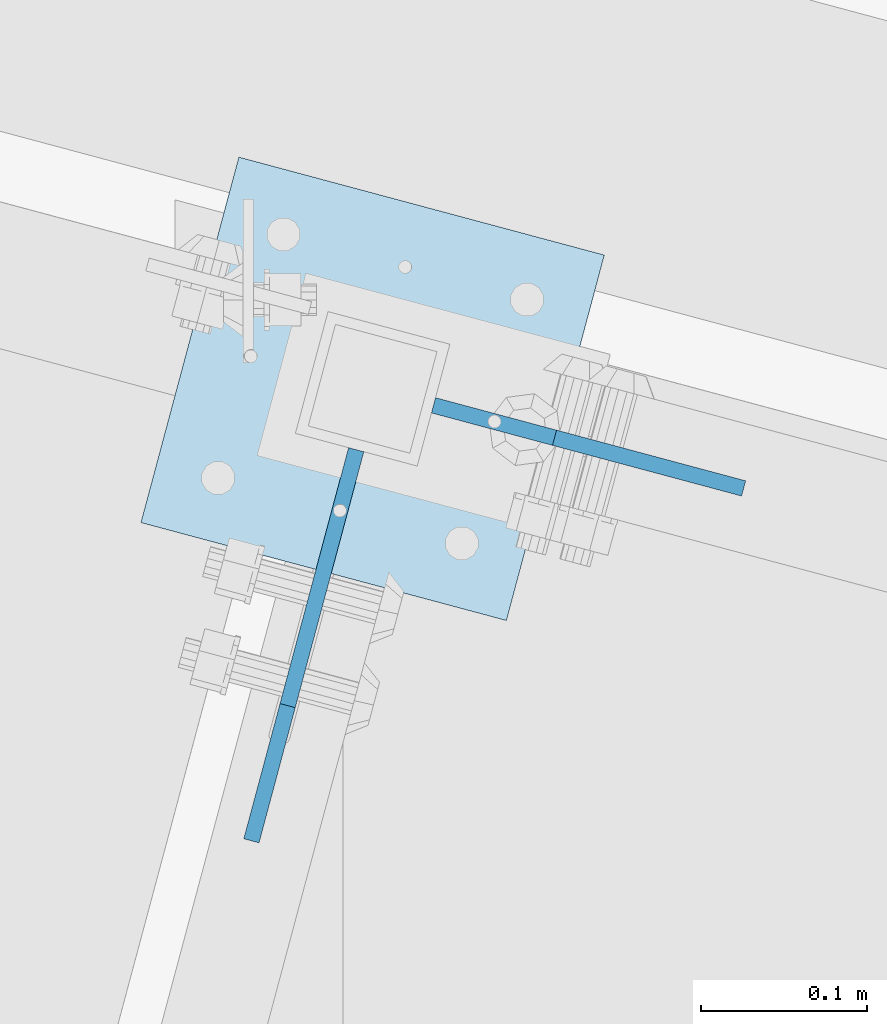
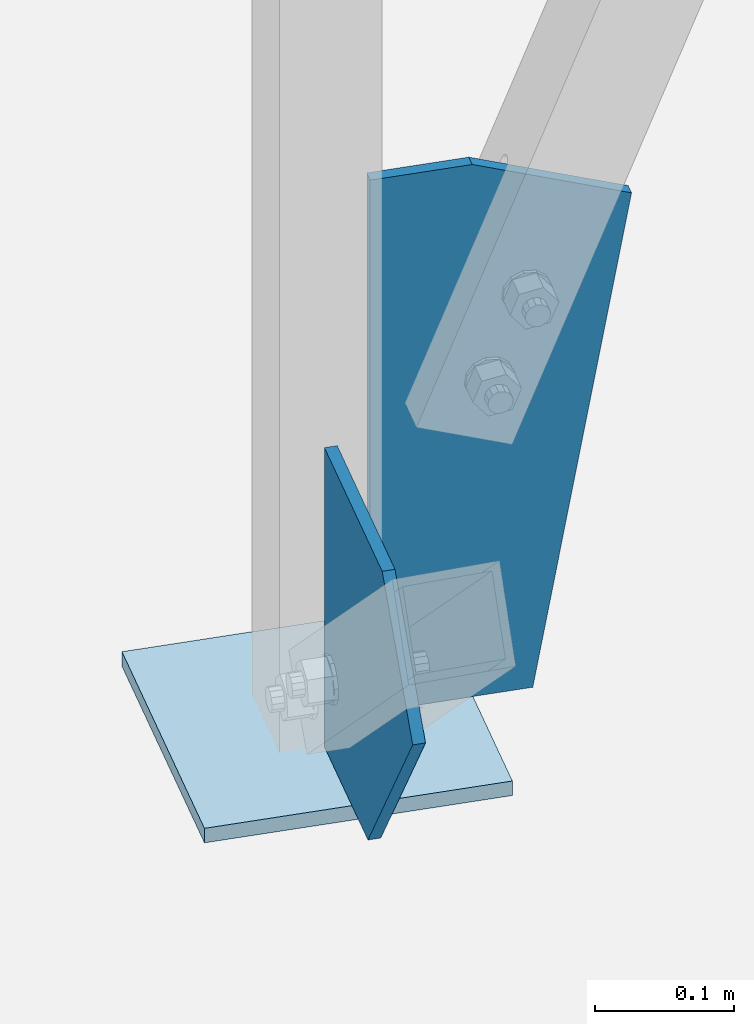
# One storey, part 1696 of 1763: 3 plates, 1 element without a shape of its own.
"""IFC2X3 building model written with IfcOpenShell, lengths in millimetres."""

from ifc_helpers import new_model, si_unit, frame, origin_with_axes, place, context, subcontext, project, spatial, faceted_brep, material, type_object, element, aggregate, save


model = new_model("IFC2X3")

# Units and contexts
model_context = context("Model", 3, precision=1e-05, world=origin_with_axes())
body_context = subcontext(model_context, "Body", "Model", "MODEL_VIEW")
ifc_project = project(units=[si_unit("LENGTHUNIT", "METRE", prefix="MILLI"), si_unit("AREAUNIT", "SQUARE_METRE"), si_unit("VOLUMEUNIT", "CUBIC_METRE"), si_unit("MASSUNIT", "GRAM", prefix="KILO"), si_unit("TIMEUNIT", "SECOND"), si_unit("PLANEANGLEUNIT", "RADIAN"), si_unit("SOLIDANGLEUNIT", "STERADIAN"), si_unit("THERMODYNAMICTEMPERATUREUNIT", "DEGREE_CELSIUS"), si_unit("LUMINOUSINTENSITYUNIT", "LUMEN")], contexts=[model_context])

# Site, building, storey
site_placement = place(None, origin_with_axes())
site = spatial("IfcSite", under=ifc_project, at=site_placement, CompositionType="ELEMENT")
building_placement = place(site_placement, origin_with_axes())
building = spatial("IfcBuilding", under=site, at=building_placement, Name="Undefined", CompositionType="ELEMENT")
storey_placement = place(building_placement, origin_with_axes())
storey = spatial("IfcBuildingStorey", under=building, at=storey_placement, Name="Undefined", CompositionType="ELEMENT", Elevation=0.0)

# Assembly, plates
assembly_placement = place(storey_placement, origin_with_axes())
assembly = element("IfcElementAssembly", 1, at=assembly_placement, inside=storey, Name="COLUMN", AssemblyPlace="NOTDEFINED", PredefinedType="RIGID_FRAME")
ifc_material = material(Name="STEEL/A36")
plate_type_1 = type_object("IfcPlateType", PredefinedType="NOTDEFINED")
plate_1_placement = place(assembly_placement, frame((-27759.8122942938, 63170.6287278392, -260.349999999996), z_axis=(0.258819045079128, 0.965925826295336, 0.0), x_axis=(0.965925826295336, -0.25881904507913, 0.0)))
plate_1 = element("IfcPlate", 2, at=plate_1_placement, type_object=plate_type_1, material=ifc_material, Name="PLATE", context=body_context, shape_type="Brep", body=[
    faceted_brep([(0.0, -6.34999999999491, 1.45519152283669e-11), (0.0, -6.35000000001855, 228.600006104178), (0.0, 6.34999999996944, 228.600006104134), (0.0, 6.34999999999491, -2.91038304567337e-11), (228.600006103363, -6.34999999999999, 228.600006104673), (228.600006103363, 6.35000000000002, 228.600006104673), (228.600006103565, -6.34999999936554, -7.49423634260893e-10), (228.600006103557, 6.35000000064611, -7.13043846189976e-10)], [[[0, 1, 2, 3]], [[1, 4, 5, 2]], [[4, 6, 7, 5]], [[6, 0, 3, 7]], [[5, 7, 3, 2]], [[6, 4, 1, 0]]]),
])
plate_type_2 = type_object("IfcPlateType", PredefinedType="NOTDEFINED")
plate_2_placement = place(assembly_placement, frame((-27629.7352970639, 63214.6627464282, -254.000000000129), z_axis=(-0.258865912030778, -0.965913267114844, 3.00823476209188e-08), x_axis=(0.0, 0.0, 1.0)))
plate_2 = element("IfcPlate", 3, at=plate_2_placement, type_object=plate_type_2, material=ifc_material, Name="PLATE", context=body_context, shape_type="Brep", body=[
    faceted_brep([(0.0, -4.76249999999982, 0.0), (3.8198777474463e-11, -4.76249999978609, 120.649999999834), (3.45607986673713e-11, 4.76250000024447, 120.649999999841), (0.0, 4.76249999999982, 0.0), (167.130142211909, -4.76250000001892, 244.657028198359), (167.130142211909, 4.76249999997526, 244.657028198359), (261.885925292964, -4.76250000033178, 160.097076416278), (261.885925292964, 4.76249999966967, 160.097076416263), (261.885925292966, -4.76250000054279, 3.12866177409887e-10), (261.885925292966, 4.76249999945867, 2.9831426218152e-10)], [[[0, 1, 2, 3]], [[1, 4, 5, 2]], [[4, 6, 7, 5]], [[6, 8, 9, 7]], [[8, 0, 3, 9]], [[5, 7, 9, 3, 2]], [[8, 6, 4, 1, 0]]]),
])
plate_type_3 = type_object("IfcPlateType", PredefinedType="NOTDEFINED")
plate_3_placement = place(assembly_placement, frame((-27583.0497555757, 63241.4871195099, 211.751491483577), z_axis=(0.965913267114843, -0.258865912030785, 0.0), x_axis=(0.0, 0.0, -1.0)))
plate_3 = element("IfcPlate", 4, at=plate_3_placement, type_object=plate_type_3, material=ifc_material, Name="PLATE", context=body_context, shape_type="Brep", body=[
    faceted_brep([(0.0, -4.76249999999982, 0.0), (7.67386154620908e-13, -4.76249999985157, 75.7163848875716), (7.67386154620908e-13, 4.76250000017171, 75.7163848875789), (0.0, 4.76249999999982, 0.0), (46.2334365844727, -4.76249999962602, 194.001922607131), (46.2334365844727, 4.76250000040454, 194.001922607138), (465.751495361328, -4.76249999977153, 120.65000152569), (465.751495361328, 4.76250000025175, 120.650001525704), (465.751495361328, -4.76250000001164, -7.27595761418343e-12), (465.751495361328, 4.76250000002619, 0.0)], [[[0, 1, 2, 3]], [[1, 4, 5, 2]], [[4, 6, 7, 5]], [[6, 8, 9, 7]], [[8, 0, 3, 9]], [[5, 7, 9, 3, 2]], [[8, 6, 4, 1, 0]]]),
])
aggregate(assembly, [plate_3, plate_2, plate_1])

save(model, "model.ifc")
